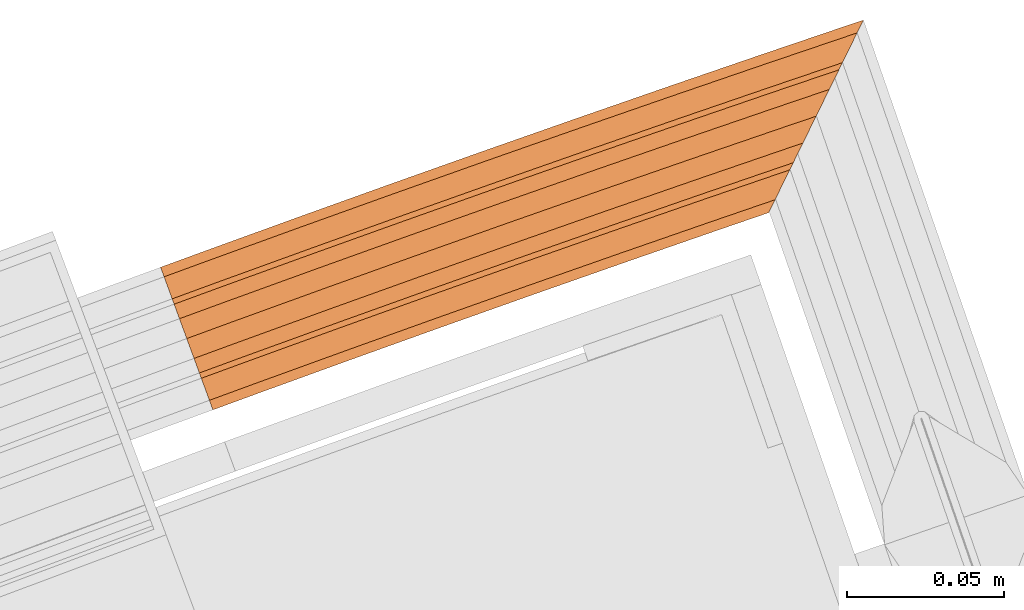
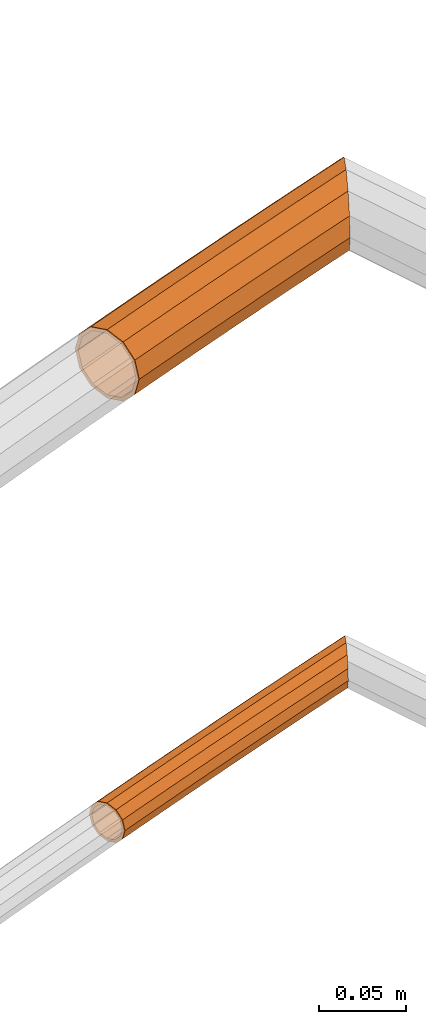
# One storey, part 102 of 126: 2 proxies.
"""IFC2X3 building model written with IfcOpenShell, lengths in millimetres."""

from ifc_helpers import new_model, si_unit, origin, origin_with_axes, place, context, project, spatial, faceted_brep, material, element, save


model = new_model("IFC2X3")

# Units and contexts
context_of_model_1 = context(None, 3, precision=0.1, world=origin())
context_of_model_2 = context(None, 3, precision=0.1, world=origin())
ifc_project = project(units=[si_unit("LENGTHUNIT", "METRE", prefix="MILLI"), si_unit("AREAUNIT", "SQUARE_METRE", prefix="CENTI"), si_unit("VOLUMEUNIT", "CUBIC_METRE", prefix="CENTI"), si_unit("MASSUNIT", "GRAM", prefix="KILO")], contexts=[context_of_model_1, context_of_model_2])

# Site, building, storey
site_placement = place(None, origin_with_axes())
site = spatial("IfcSite", under=ifc_project, at=site_placement, CompositionType="ELEMENT")
building_placement = place(site_placement, origin_with_axes())
building = spatial("IfcBuilding", under=site, at=building_placement, CompositionType="ELEMENT")
storey_placement = place(building_placement, origin_with_axes())
storey = spatial("IfcBuildingStorey", under=building, at=storey_placement, CompositionType="ELEMENT")

# Proxies
ifc_material = material(Name="S235JRG2")
proxy_1_placement = place(storey_placement, origin_with_axes())
element("IfcBuildingElementProxy", 1, at=proxy_1_placement, inside=storey, material=ifc_material, Name="HANDLAUF", context=context_of_model_2, shape_type="Brep", body=[
    faceted_brep([(4959.2389, 16355.017, 12161.0), (4960.3476, 16351.978, 12148.925), (4945.7876, 16346.638, 12148.925), (4944.6736, 16349.676, 12161.0), (4963.3767, 16343.674, 12140.085), (4948.8311, 16338.339, 12140.085), (4967.5145, 16332.33, 12136.85), (4952.9885, 16327.002, 12136.85), (4971.6523, 16320.986, 12140.085), (4957.146, 16315.666, 12140.085), (4974.6814, 16312.681, 12148.925), (4960.1895, 16307.367, 12148.925), (4975.7902, 16309.642, 12161.0), (4961.3035, 16304.329, 12161.0), (4974.6814, 16312.681, 12173.075), (4960.1895, 16307.367, 12173.075), (4971.6523, 16320.986, 12181.915), (4957.146, 16315.666, 12181.915), (4967.5145, 16332.33, 12185.15), (4952.9885, 16327.002, 12185.15), (4963.3767, 16343.674, 12181.915), (4948.8311, 16338.339, 12181.915), (4960.3476, 16351.978, 12173.075), (4945.7876, 16346.638, 12173.075), (4960.0956, 16352.669, 12161.0), (4961.0895, 16349.944, 12171.825), (4946.533, 16344.605, 12171.825), (4945.5343, 16347.329, 12161.0), (4963.805, 16342.499, 12179.749), (4949.2614, 16337.165, 12179.749), (4967.5145, 16332.33, 12182.65), (4952.9885, 16327.002, 12182.65), (4971.224, 16322.16, 12179.749), (4956.7156, 16316.839, 12179.749), (4973.9395, 16314.715, 12171.825), (4959.4441, 16309.399, 12171.825), (4974.9335, 16311.99, 12161.0), (4960.4428, 16306.676, 12161.0), (4973.9395, 16314.715, 12150.175), (4959.4441, 16309.399, 12150.175), (4971.224, 16322.16, 12142.251), (4956.7156, 16316.839, 12142.251), (4967.5145, 16332.33, 12139.35), (4952.9885, 16327.002, 12139.35), (4963.805, 16342.499, 12142.251), (4949.2614, 16337.165, 12142.251), (4961.0895, 16349.944, 12150.175), (4946.533, 16344.605, 12150.175), (4988.4044, 16365.598, 12161.0), (4989.5025, 16362.555, 12148.925), (4992.5026, 16354.24, 12140.085), (4996.6008, 16342.882, 12136.85), (5000.699, 16331.523, 12140.085), (5003.6991, 16323.209, 12148.925), (5004.7972, 16320.165, 12161.0), (5003.6991, 16323.209, 12173.075), (5000.699, 16331.523, 12181.915), (4996.6008, 16342.882, 12185.15), (4992.5026, 16354.24, 12181.915), (4989.5025, 16362.555, 12173.075), (4989.2529, 16363.247, 12161.0), (4990.2374, 16360.518, 12171.825), (4992.9269, 16353.064, 12179.749), (4996.6008, 16342.882, 12182.65), (5000.2748, 16332.699, 12179.749), (5002.9643, 16325.245, 12171.825), (5003.9487, 16322.517, 12161.0), (5002.9643, 16325.245, 12150.175), (5000.2748, 16332.699, 12142.251), (4996.6008, 16342.882, 12139.35), (4992.9269, 16353.064, 12142.251), (4990.2374, 16360.518, 12150.175), (5017.6067, 16376.077, 12161.0), (5018.6942, 16373.03, 12148.925), (5021.6653, 16364.705, 12140.085), (5025.7238, 16353.332, 12136.85), (5029.7823, 16341.96, 12140.085), (5032.7534, 16333.634, 12148.925), (5033.8408, 16330.587, 12161.0), (5032.7534, 16333.634, 12173.075), (5029.7823, 16341.96, 12181.915), (5025.7238, 16353.332, 12185.15), (5021.6653, 16364.705, 12181.915), (5018.6942, 16373.03, 12173.075), (5018.447, 16373.723, 12161.0), (5019.4219, 16370.991, 12171.825), (5022.0854, 16363.527, 12179.749), (5025.7238, 16353.332, 12182.65), (5029.3622, 16343.137, 12179.749), (5032.0257, 16335.673, 12171.825), (5033.0006, 16332.942, 12161.0), (5032.0257, 16335.673, 12150.175), (5029.3622, 16343.137, 12142.251), (5025.7238, 16353.332, 12139.35), (5022.0854, 16363.527, 12142.251), (5019.4219, 16370.991, 12150.175), (5046.8455, 16386.454, 12161.0), (5047.9223, 16383.403, 12148.925), (5050.8643, 16375.067, 12140.085), (5054.8831, 16363.681, 12136.85), (5058.9019, 16352.294, 12140.085), (5061.8438, 16343.959, 12148.925), (5062.9207, 16340.908, 12161.0), (5061.8438, 16343.959, 12173.075), (5058.9019, 16352.294, 12181.915), (5054.8831, 16363.681, 12185.15), (5050.8643, 16375.067, 12181.915), (5047.9223, 16383.403, 12173.075), (5047.6775, 16384.097, 12161.0), (5048.6429, 16381.361, 12171.825), (5051.2803, 16373.889, 12179.749), (5054.8831, 16363.681, 12182.65), (5058.4858, 16353.473, 12179.749), (5061.1233, 16346.0, 12171.825), (5062.0886, 16343.265, 12161.0), (5061.1233, 16346.0, 12150.175), (5058.4858, 16353.473, 12142.251), (5054.8831, 16363.681, 12139.35), (5051.2803, 16373.889, 12142.251), (5048.6429, 16381.361, 12150.175), (5076.1202, 16396.729, 12161.0), (5077.1864, 16393.674, 12148.925), (5080.0992, 16385.328, 12140.085), (5084.0783, 16373.928, 12136.85), (5088.0573, 16362.527, 12140.085), (5090.9702, 16354.181, 12148.925), (5092.0363, 16351.127, 12161.0), (5090.9702, 16354.181, 12173.075), (5088.0573, 16362.527, 12181.915), (5084.0783, 16373.928, 12185.15), (5080.0992, 16385.328, 12181.915), (5077.1864, 16393.674, 12173.075), (5076.944, 16394.369, 12161.0), (5077.8998, 16391.63, 12171.825), (5080.5112, 16384.148, 12179.749), (5084.0783, 16373.928, 12182.65), (5087.6454, 16363.707, 12179.749), (5090.2567, 16356.226, 12171.825), (5091.2125, 16353.487, 12161.0), (5090.2567, 16356.226, 12150.175), (5087.6454, 16363.707, 12142.251), (5084.0783, 16373.928, 12139.35), (5080.5112, 16384.148, 12142.251), (5077.8998, 16391.63, 12150.175), (5105.4307, 16406.902, 12161.0), (5106.4862, 16403.843, 12148.925), (5109.3699, 16395.487, 12140.085), (5113.3091, 16384.073, 12136.85), (5117.2483, 16372.658, 12140.085), (5120.132, 16364.302, 12148.925), (5121.1875, 16361.244, 12161.0), (5120.132, 16364.302, 12173.075), (5117.2483, 16372.658, 12181.915), (5113.3091, 16384.073, 12185.15), (5109.3699, 16395.487, 12181.915), (5106.4862, 16403.843, 12173.075), (5106.2462, 16404.538, 12161.0), (5107.1925, 16401.796, 12171.825), (5109.7777, 16394.305, 12179.749), (5113.3091, 16384.073, 12182.65), (5116.8405, 16373.84, 12179.749), (5119.4257, 16366.349, 12171.825), (5120.3719, 16363.607, 12161.0), (5119.4257, 16366.349, 12150.175), (5116.8405, 16373.84, 12142.251), (5113.3091, 16384.073, 12139.35), (5109.7777, 16394.305, 12142.251), (5107.1925, 16401.796, 12150.175), (5134.7764, 16416.972, 12161.0), (5135.8213, 16413.91, 12148.925), (5138.6758, 16405.544, 12140.085), (5142.5751, 16394.116, 12136.85), (5146.177, 16383.559, 12139.839), (5145.601, 16382.388, 12140.085), (5140.0734, 16371.145, 12148.925), (5138.0501, 16367.03, 12161.0), (5140.0734, 16371.145, 12173.075), (5145.601, 16382.388, 12181.915), (5146.177, 16383.559, 12182.161), (5142.5751, 16394.116, 12185.15), (5138.6758, 16405.544, 12181.915), (5135.8213, 16413.91, 12173.075), (5135.5838, 16414.606, 12161.0), (5136.5204, 16411.86, 12171.825), (5139.0794, 16404.361, 12179.749), (5142.5751, 16394.116, 12182.65), (5146.0708, 16383.871, 12179.749), (5146.177, 16383.559, 12179.421), (5141.4272, 16373.899, 12171.825), (5139.6134, 16370.21, 12161.0), (5141.4272, 16373.899, 12150.175), (5146.177, 16383.559, 12142.579), (5146.0708, 16383.871, 12142.251), (5142.5751, 16394.116, 12139.35), (5139.0794, 16404.361, 12142.251), (5136.5204, 16411.86, 12150.175), (5164.1572, 16426.939, 12161.0), (5165.1913, 16423.874, 12148.925), (5165.5199, 16422.9, 12147.897), (5160.6521, 16412.999, 12140.085), (5153.1276, 16397.696, 12136.85), (5153.1276, 16397.696, 12185.15), (5160.6521, 16412.999, 12181.915), (5165.5199, 16422.9, 12174.103), (5165.1913, 16423.874, 12173.075), (5164.9562, 16424.571, 12161.0), (5165.5199, 16422.9, 12167.581), (5164.8113, 16421.458, 12171.825), (5159.8732, 16411.415, 12179.749), (5153.1276, 16397.696, 12182.65), (5146.3819, 16383.976, 12179.749), (5146.3819, 16383.976, 12142.251), (5153.1276, 16397.696, 12139.35), (5159.8732, 16411.415, 12142.251), (5164.8113, 16421.458, 12150.175), (5165.5199, 16422.9, 12154.419), (5168.1675, 16428.284, 12161.0), (5166.1583, 16424.198, 12148.925), (5166.1583, 16424.198, 12173.075), (5166.615, 16425.127, 12161.0)], [[[0, 1, 2, 3]], [[1, 4, 5, 2]], [[4, 6, 7, 5]], [[6, 8, 9, 7]], [[8, 10, 11, 9]], [[10, 12, 13, 11]], [[12, 14, 15, 13]], [[14, 16, 17, 15]], [[16, 18, 19, 17]], [[18, 20, 21, 19]], [[20, 22, 23, 21]], [[0, 3, 23, 22]], [[24, 25, 26, 27]], [[25, 28, 29, 26]], [[28, 30, 31, 29]], [[30, 32, 33, 31]], [[32, 34, 35, 33]], [[34, 36, 37, 35]], [[36, 38, 39, 37]], [[38, 40, 41, 39]], [[40, 42, 43, 41]], [[42, 44, 45, 43]], [[44, 46, 47, 45]], [[24, 27, 47, 46]], [[0, 48, 49, 1]], [[1, 49, 50, 4]], [[4, 50, 51, 6]], [[6, 51, 52, 8]], [[8, 52, 53, 10]], [[10, 53, 54, 12]], [[12, 54, 55, 14]], [[14, 55, 56, 16]], [[16, 56, 57, 18]], [[18, 57, 58, 20]], [[20, 58, 59, 22]], [[22, 59, 48, 0]], [[24, 60, 61, 25]], [[25, 61, 62, 28]], [[28, 62, 63, 30]], [[30, 63, 64, 32]], [[32, 64, 65, 34]], [[34, 65, 66, 36]], [[36, 66, 67, 38]], [[38, 67, 68, 40]], [[40, 68, 69, 42]], [[42, 69, 70, 44]], [[44, 70, 71, 46]], [[46, 71, 60, 24]], [[48, 72, 73, 49]], [[49, 73, 74, 50]], [[50, 74, 75, 51]], [[51, 75, 76, 52]], [[52, 76, 77, 53]], [[53, 77, 78, 54]], [[54, 78, 79, 55]], [[55, 79, 80, 56]], [[56, 80, 81, 57]], [[57, 81, 82, 58]], [[58, 82, 83, 59]], [[59, 83, 72, 48]], [[60, 84, 85, 61]], [[61, 85, 86, 62]], [[62, 86, 87, 63]], [[63, 87, 88, 64]], [[64, 88, 89, 65]], [[65, 89, 90, 66]], [[66, 90, 91, 67]], [[67, 91, 92, 68]], [[68, 92, 93, 69]], [[69, 93, 94, 70]], [[70, 94, 95, 71]], [[71, 95, 84, 60]], [[72, 96, 97, 73]], [[73, 97, 98, 74]], [[74, 98, 99, 75]], [[75, 99, 100, 76]], [[76, 100, 101, 77]], [[77, 101, 102, 78]], [[78, 102, 103, 79]], [[79, 103, 104, 80]], [[80, 104, 105, 81]], [[81, 105, 106, 82]], [[82, 106, 107, 83]], [[83, 107, 96, 72]], [[84, 108, 109, 85]], [[85, 109, 110, 86]], [[86, 110, 111, 87]], [[87, 111, 112, 88]], [[88, 112, 113, 89]], [[89, 113, 114, 90]], [[90, 114, 115, 91]], [[91, 115, 116, 92]], [[92, 116, 117, 93]], [[93, 117, 118, 94]], [[94, 118, 119, 95]], [[95, 119, 108, 84]], [[96, 120, 121, 97]], [[97, 121, 122, 98]], [[98, 122, 123, 99]], [[99, 123, 124, 100]], [[100, 124, 125, 101]], [[101, 125, 126, 102]], [[102, 126, 127, 103]], [[103, 127, 128, 104]], [[104, 128, 129, 105]], [[105, 129, 130, 106]], [[106, 130, 131, 107]], [[107, 131, 120, 96]], [[108, 132, 133, 109]], [[109, 133, 134, 110]], [[110, 134, 135, 111]], [[111, 135, 136, 112]], [[112, 136, 137, 113]], [[113, 137, 138, 114]], [[114, 138, 139, 115]], [[115, 139, 140, 116]], [[116, 140, 141, 117]], [[117, 141, 142, 118]], [[118, 142, 143, 119]], [[119, 143, 132, 108]], [[120, 144, 145, 121]], [[121, 145, 146, 122]], [[122, 146, 147, 123]], [[123, 147, 148, 124]], [[124, 148, 149, 125]], [[125, 149, 150, 126]], [[126, 150, 151, 127]], [[127, 151, 152, 128]], [[128, 152, 153, 129]], [[129, 153, 154, 130]], [[130, 154, 155, 131]], [[131, 155, 144, 120]], [[132, 156, 157, 133]], [[133, 157, 158, 134]], [[134, 158, 159, 135]], [[135, 159, 160, 136]], [[136, 160, 161, 137]], [[137, 161, 162, 138]], [[138, 162, 163, 139]], [[139, 163, 164, 140]], [[140, 164, 165, 141]], [[141, 165, 166, 142]], [[142, 166, 167, 143]], [[143, 167, 156, 132]], [[144, 168, 169, 145]], [[145, 169, 170, 146]], [[146, 170, 171, 147]], [[148, 147, 171, 172, 173]], [[148, 173, 174, 149]], [[149, 174, 175, 150]], [[150, 175, 176, 151]], [[151, 176, 177, 152]], [[152, 177, 178, 179, 153]], [[153, 179, 180, 154]], [[154, 180, 181, 155]], [[155, 181, 168, 144]], [[156, 182, 183, 157]], [[157, 183, 184, 158]], [[158, 184, 185, 159]], [[159, 185, 186, 160]], [[161, 160, 186, 187, 188]], [[161, 188, 189, 162]], [[162, 189, 190, 163]], [[163, 190, 191, 192, 164]], [[164, 192, 193, 165]], [[165, 193, 194, 166]], [[166, 194, 195, 167]], [[167, 195, 182, 156]], [[168, 196, 197, 169]], [[170, 169, 197, 198, 199]], [[170, 199, 200, 171]], [[171, 200, 172]], [[178, 201, 179]], [[179, 201, 202, 180]], [[180, 202, 203, 204, 181]], [[181, 204, 196, 168]], [[183, 182, 205, 206, 207]], [[183, 207, 208, 184]], [[184, 208, 209, 185]], [[185, 209, 210, 186]], [[186, 210, 187]], [[191, 211, 192]], [[192, 211, 212, 193]], [[193, 212, 213, 194]], [[194, 213, 214, 195]], [[195, 214, 215, 205, 182]], [[196, 216, 217, 197]], [[197, 217, 198]], [[203, 218, 204]], [[196, 204, 218, 216]], [[205, 219, 206]], [[205, 215, 219]], [[13, 15, 17, 19, 21, 23, 3, 2, 5, 7, 9, 11], [26, 29, 31, 33, 35, 37, 39, 41, 43, 45, 47, 27]], [[175, 174, 173, 172, 200, 199, 198, 217, 216, 218, 203, 202, 201, 178, 177, 176], [187, 210, 209, 208, 207, 206, 219, 215, 214, 213, 212, 211, 191, 190, 189, 188]]]),
])
proxy_2_placement = place(storey_placement, origin_with_axes())
element("IfcBuildingElementProxy", 2, at=proxy_2_placement, inside=storey, material=ifc_material, context=context_of_model_2, shape_type="Brep", body=[
    faceted_brep([(4962.9055, 16344.965, 11838.155), (4963.523, 16343.272, 11831.43), (4948.9781, 16337.938, 11831.43), (4948.3576, 16339.63, 11838.155), (4965.21, 16338.647, 11826.507), (4950.6731, 16333.316, 11826.507), (4967.5145, 16332.33, 11824.705), (4952.9885, 16327.002, 11824.705), (4969.819, 16326.012, 11826.507), (4955.304, 16320.689, 11826.507), (4971.506, 16321.387, 11831.43), (4956.999, 16316.066, 11831.43), (4972.1235, 16319.694, 11838.155), (4957.6195, 16314.375, 11838.155), (4971.506, 16321.387, 11844.88), (4956.999, 16316.066, 11844.88), (4969.819, 16326.012, 11849.803), (4955.304, 16320.689, 11849.803), (4967.5145, 16332.33, 11851.605), (4952.9885, 16327.002, 11851.605), (4965.21, 16338.647, 11849.803), (4950.6731, 16333.316, 11849.803), (4963.523, 16343.272, 11844.88), (4948.9781, 16337.938, 11844.88), (4963.5909, 16343.086, 11838.155), (4964.1165, 16341.645, 11843.88), (4949.5744, 16336.312, 11843.88), (4949.0462, 16337.752, 11838.155), (4965.5527, 16337.708, 11848.071), (4951.0174, 16332.377, 11848.071), (4967.5145, 16332.33, 11849.605), (4952.9885, 16327.002, 11849.605), (4969.4763, 16326.951, 11848.071), (4954.9597, 16321.627, 11848.071), (4970.9125, 16323.014, 11843.88), (4956.4027, 16317.693, 11843.88), (4971.4382, 16321.573, 11838.155), (4956.9308, 16316.252, 11838.155), (4970.9125, 16323.014, 11832.43), (4956.4027, 16317.693, 11832.43), (4969.4763, 16326.951, 11828.239), (4954.9597, 16321.627, 11828.239), (4967.5145, 16332.33, 11826.705), (4952.9885, 16327.002, 11826.705), (4965.5527, 16337.708, 11828.239), (4951.0174, 16332.377, 11828.239), (4964.1165, 16341.645, 11832.43), (4949.5744, 16336.312, 11832.43), (4992.036, 16355.533, 11838.155), (4992.6475, 16353.838, 11831.43), (4994.3184, 16349.208, 11826.507), (4996.6008, 16342.882, 11824.705), (4998.8833, 16336.556, 11826.507), (5000.5541, 16331.925, 11831.43), (5001.1657, 16330.23, 11838.155), (5000.5541, 16331.925, 11844.88), (4998.8833, 16336.556, 11849.803), (4996.6008, 16342.882, 11851.605), (4994.3184, 16349.208, 11849.803), (4992.6475, 16353.838, 11844.88), (4992.7148, 16353.652, 11838.155), (4993.2354, 16352.209, 11843.88), (4994.6578, 16348.267, 11848.071), (4996.6008, 16342.882, 11849.605), (4998.5439, 16337.496, 11848.071), (4999.9663, 16333.554, 11843.88), (5000.4869, 16332.111, 11838.155), (4999.9663, 16333.554, 11832.43), (4998.5439, 16337.496, 11828.239), (4996.6008, 16342.882, 11826.705), (4994.6578, 16348.267, 11828.239), (4993.2354, 16352.209, 11832.43), (5021.2031, 16366.0, 11838.155), (5021.8088, 16364.303, 11831.43), (5023.4635, 16359.666, 11826.507), (5025.7238, 16353.332, 11824.705), (5027.9841, 16346.998, 11826.507), (5029.6388, 16342.362, 11831.43), (5030.2445, 16340.665, 11838.155), (5029.6388, 16342.362, 11844.88), (5027.9841, 16346.998, 11849.803), (5025.7238, 16353.332, 11851.605), (5023.4635, 16359.666, 11849.803), (5021.8088, 16364.303, 11844.88), (5021.8753, 16364.116, 11838.155), (5022.3909, 16362.671, 11843.88), (5023.7996, 16358.724, 11848.071), (5025.7238, 16353.332, 11849.605), (5027.648, 16347.94, 11848.071), (5029.0567, 16343.993, 11843.88), (5029.5723, 16342.548, 11838.155), (5029.0567, 16343.993, 11832.43), (5027.648, 16347.94, 11828.239), (5025.7238, 16353.332, 11826.705), (5023.7996, 16358.724, 11828.239), (5022.3909, 16362.671, 11832.43), (5050.4066, 16376.364, 11838.155), (5051.0064, 16374.665, 11831.43), (5052.6448, 16370.022, 11826.507), (5054.8831, 16363.681, 11824.705), (5057.1213, 16357.339, 11826.507), (5058.7598, 16352.697, 11831.43), (5059.3595, 16350.998, 11838.155), (5058.7598, 16352.697, 11844.88), (5057.1213, 16357.339, 11849.803), (5054.8831, 16363.681, 11851.605), (5052.6448, 16370.022, 11849.803), (5051.0064, 16374.665, 11844.88), (5051.0723, 16374.478, 11838.155), (5051.5828, 16373.031, 11843.88), (5052.9777, 16369.08, 11848.071), (5054.8831, 16363.681, 11849.605), (5056.7885, 16358.282, 11848.071), (5058.1833, 16354.33, 11843.88), (5058.6939, 16352.884, 11838.155), (5058.1833, 16354.33, 11832.43), (5056.7885, 16358.282, 11828.239), (5054.8831, 16363.681, 11826.705), (5052.9777, 16369.08, 11828.239), (5051.5828, 16373.031, 11832.43), (5079.6461, 16386.626, 11838.155), (5080.2399, 16384.925, 11831.43), (5081.8622, 16380.277, 11826.507), (5084.0783, 16373.928, 11824.705), (5086.2943, 16367.578, 11826.507), (5087.9166, 16362.93, 11831.43), (5088.5104, 16361.229, 11838.155), (5087.9166, 16362.93, 11844.88), (5086.2943, 16367.578, 11849.803), (5084.0783, 16373.928, 11851.605), (5081.8622, 16380.277, 11849.803), (5080.2399, 16384.925, 11844.88), (5080.3052, 16384.738, 11838.155), (5080.8107, 16383.29, 11843.88), (5082.1917, 16379.333, 11848.071), (5084.0783, 16373.928, 11849.605), (5085.9648, 16368.522, 11848.071), (5087.3459, 16364.566, 11843.88), (5087.8514, 16363.117, 11838.155), (5087.3459, 16364.566, 11832.43), (5085.9648, 16368.522, 11828.239), (5084.0783, 16373.928, 11826.705), (5082.1917, 16379.333, 11828.239), (5080.8107, 16383.29, 11832.43), (5108.9213, 16396.787, 11838.155), (5109.5092, 16395.084, 11831.43), (5111.1152, 16390.43, 11826.507), (5113.3091, 16384.073, 11824.705), (5115.503, 16377.716, 11826.507), (5117.109, 16373.062, 11831.43), (5117.6969, 16371.359, 11838.155), (5117.109, 16373.062, 11844.88), (5115.503, 16377.716, 11849.803), (5113.3091, 16384.073, 11851.605), (5111.1152, 16390.43, 11849.803), (5109.5092, 16395.084, 11844.88), (5109.5738, 16394.896, 11838.155), (5110.0742, 16393.446, 11843.88), (5111.4414, 16389.484, 11848.071), (5113.3091, 16384.073, 11849.605), (5115.1767, 16378.661, 11848.071), (5116.544, 16374.699, 11843.88), (5117.0444, 16373.249, 11838.155), (5116.544, 16374.699, 11832.43), (5115.1767, 16378.661, 11828.239), (5113.3091, 16384.073, 11826.705), (5111.4414, 16389.484, 11828.239), (5110.0742, 16393.446, 11832.43), (5138.2318, 16406.845, 11838.155), (5138.8137, 16405.14, 11831.43), (5140.4034, 16400.48, 11826.507), (5142.5751, 16394.116, 11824.705), (5144.7468, 16387.751, 11826.507), (5146.177, 16383.559, 11830.936), (5145.868, 16382.931, 11831.43), (5144.7412, 16380.639, 11838.155), (5145.868, 16382.931, 11844.88), (5146.177, 16383.559, 11845.374), (5144.7468, 16387.751, 11849.803), (5142.5751, 16394.116, 11851.605), (5140.4034, 16400.48, 11849.803), (5138.8137, 16405.14, 11844.88), (5138.8776, 16404.952, 11838.155), (5139.373, 16403.5, 11843.88), (5140.7264, 16399.534, 11848.071), (5142.5751, 16394.116, 11849.605), (5144.4239, 16388.697, 11848.071), (5145.7773, 16384.731, 11843.88), (5146.177, 16383.559, 11839.26), (5145.9918, 16383.183, 11838.155), (5146.177, 16383.559, 11837.05), (5145.7773, 16384.731, 11832.43), (5144.4239, 16388.697, 11828.239), (5142.5751, 16394.116, 11826.705), (5140.7264, 16399.534, 11828.239), (5139.373, 16403.5, 11832.43), (5161.509, 16414.742, 11838.155), (5160.3861, 16412.458, 11831.43), (5157.3183, 16406.219, 11826.507), (5153.1276, 16397.696, 11824.705), (5148.9369, 16389.172, 11826.507), (5148.9369, 16389.172, 11849.803), (5153.1276, 16397.696, 11851.605), (5157.3183, 16406.219, 11849.803), (5160.3861, 16412.458, 11844.88), (5160.2627, 16412.207, 11838.155), (5159.3067, 16410.263, 11843.88), (5156.6951, 16404.951, 11848.071), (5153.1276, 16397.696, 11849.605), (5149.56, 16390.44, 11848.071), (5146.9484, 16385.128, 11843.88), (5146.9484, 16385.128, 11832.43), (5149.56, 16390.44, 11828.239), (5153.1276, 16397.696, 11826.705), (5156.6951, 16404.951, 11828.239), (5159.3067, 16410.263, 11832.43)], [[[0, 1, 2, 3]], [[1, 4, 5, 2]], [[4, 6, 7, 5]], [[6, 8, 9, 7]], [[8, 10, 11, 9]], [[10, 12, 13, 11]], [[12, 14, 15, 13]], [[14, 16, 17, 15]], [[16, 18, 19, 17]], [[18, 20, 21, 19]], [[20, 22, 23, 21]], [[0, 3, 23, 22]], [[24, 25, 26, 27]], [[25, 28, 29, 26]], [[28, 30, 31, 29]], [[30, 32, 33, 31]], [[32, 34, 35, 33]], [[34, 36, 37, 35]], [[36, 38, 39, 37]], [[38, 40, 41, 39]], [[40, 42, 43, 41]], [[42, 44, 45, 43]], [[44, 46, 47, 45]], [[24, 27, 47, 46]], [[0, 48, 49, 1]], [[1, 49, 50, 4]], [[4, 50, 51, 6]], [[6, 51, 52, 8]], [[8, 52, 53, 10]], [[10, 53, 54, 12]], [[12, 54, 55, 14]], [[14, 55, 56, 16]], [[16, 56, 57, 18]], [[18, 57, 58, 20]], [[20, 58, 59, 22]], [[22, 59, 48, 0]], [[24, 60, 61, 25]], [[25, 61, 62, 28]], [[28, 62, 63, 30]], [[30, 63, 64, 32]], [[32, 64, 65, 34]], [[34, 65, 66, 36]], [[36, 66, 67, 38]], [[38, 67, 68, 40]], [[40, 68, 69, 42]], [[42, 69, 70, 44]], [[44, 70, 71, 46]], [[46, 71, 60, 24]], [[48, 72, 73, 49]], [[49, 73, 74, 50]], [[50, 74, 75, 51]], [[51, 75, 76, 52]], [[52, 76, 77, 53]], [[53, 77, 78, 54]], [[54, 78, 79, 55]], [[55, 79, 80, 56]], [[56, 80, 81, 57]], [[57, 81, 82, 58]], [[58, 82, 83, 59]], [[59, 83, 72, 48]], [[60, 84, 85, 61]], [[61, 85, 86, 62]], [[62, 86, 87, 63]], [[63, 87, 88, 64]], [[64, 88, 89, 65]], [[65, 89, 90, 66]], [[66, 90, 91, 67]], [[67, 91, 92, 68]], [[68, 92, 93, 69]], [[69, 93, 94, 70]], [[70, 94, 95, 71]], [[71, 95, 84, 60]], [[72, 96, 97, 73]], [[73, 97, 98, 74]], [[74, 98, 99, 75]], [[75, 99, 100, 76]], [[76, 100, 101, 77]], [[77, 101, 102, 78]], [[78, 102, 103, 79]], [[79, 103, 104, 80]], [[80, 104, 105, 81]], [[81, 105, 106, 82]], [[82, 106, 107, 83]], [[83, 107, 96, 72]], [[84, 108, 109, 85]], [[85, 109, 110, 86]], [[86, 110, 111, 87]], [[87, 111, 112, 88]], [[88, 112, 113, 89]], [[89, 113, 114, 90]], [[90, 114, 115, 91]], [[91, 115, 116, 92]], [[92, 116, 117, 93]], [[93, 117, 118, 94]], [[94, 118, 119, 95]], [[95, 119, 108, 84]], [[96, 120, 121, 97]], [[97, 121, 122, 98]], [[98, 122, 123, 99]], [[99, 123, 124, 100]], [[100, 124, 125, 101]], [[101, 125, 126, 102]], [[102, 126, 127, 103]], [[103, 127, 128, 104]], [[104, 128, 129, 105]], [[105, 129, 130, 106]], [[106, 130, 131, 107]], [[107, 131, 120, 96]], [[108, 132, 133, 109]], [[109, 133, 134, 110]], [[110, 134, 135, 111]], [[111, 135, 136, 112]], [[112, 136, 137, 113]], [[113, 137, 138, 114]], [[114, 138, 139, 115]], [[115, 139, 140, 116]], [[116, 140, 141, 117]], [[117, 141, 142, 118]], [[118, 142, 143, 119]], [[119, 143, 132, 108]], [[120, 144, 145, 121]], [[121, 145, 146, 122]], [[122, 146, 147, 123]], [[123, 147, 148, 124]], [[124, 148, 149, 125]], [[125, 149, 150, 126]], [[126, 150, 151, 127]], [[127, 151, 152, 128]], [[128, 152, 153, 129]], [[129, 153, 154, 130]], [[130, 154, 155, 131]], [[131, 155, 144, 120]], [[132, 156, 157, 133]], [[133, 157, 158, 134]], [[134, 158, 159, 135]], [[135, 159, 160, 136]], [[136, 160, 161, 137]], [[137, 161, 162, 138]], [[138, 162, 163, 139]], [[139, 163, 164, 140]], [[140, 164, 165, 141]], [[141, 165, 166, 142]], [[142, 166, 167, 143]], [[143, 167, 156, 132]], [[144, 168, 169, 145]], [[145, 169, 170, 146]], [[146, 170, 171, 147]], [[147, 171, 172, 148]], [[149, 148, 172, 173, 174]], [[149, 174, 175, 150]], [[150, 175, 176, 151]], [[151, 176, 177, 178, 152]], [[152, 178, 179, 153]], [[153, 179, 180, 154]], [[154, 180, 181, 155]], [[155, 181, 168, 144]], [[156, 182, 183, 157]], [[157, 183, 184, 158]], [[158, 184, 185, 159]], [[159, 185, 186, 160]], [[160, 186, 187, 161]], [[162, 161, 187, 188, 189]], [[162, 189, 190, 191, 163]], [[163, 191, 192, 164]], [[164, 192, 193, 165]], [[165, 193, 194, 166]], [[166, 194, 195, 167]], [[167, 195, 182, 156]], [[168, 196, 197, 169]], [[169, 197, 198, 170]], [[170, 198, 199, 171]], [[171, 199, 200, 172]], [[172, 200, 173]], [[177, 201, 178]], [[178, 201, 202, 179]], [[179, 202, 203, 180]], [[180, 203, 204, 181]], [[168, 181, 204, 196]], [[182, 205, 206, 183]], [[183, 206, 207, 184]], [[184, 207, 208, 185]], [[185, 208, 209, 186]], [[186, 209, 210, 187]], [[187, 210, 188]], [[190, 211, 191]], [[191, 211, 212, 192]], [[192, 212, 213, 193]], [[193, 213, 214, 194]], [[194, 214, 215, 195]], [[182, 195, 215, 205]], [[13, 15, 17, 19, 21, 23, 3, 2, 5, 7, 9, 11], [26, 29, 31, 33, 35, 37, 39, 41, 43, 45, 47, 27]], [[175, 174, 173, 200, 199, 198, 197, 196, 204, 203, 202, 201, 177, 176], [188, 210, 209, 208, 207, 206, 205, 215, 214, 213, 212, 211, 190, 189]]]),
])

save(model, "model.ifc")
